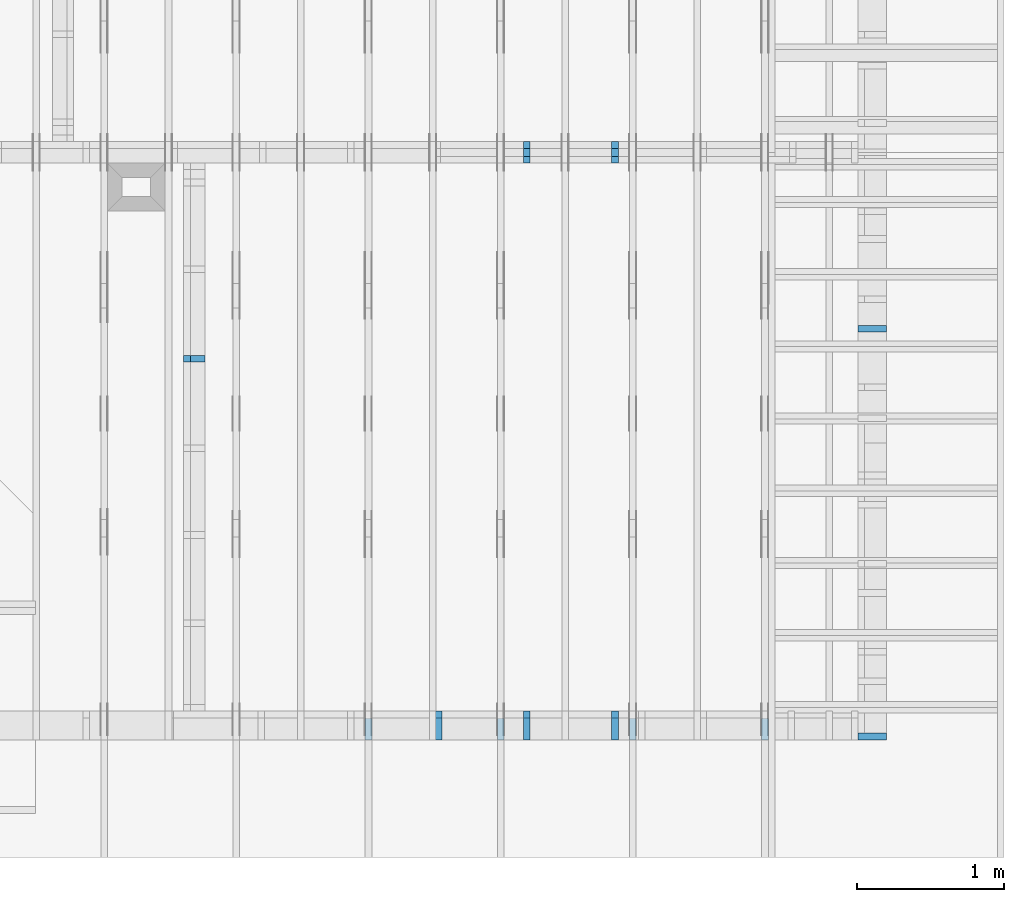
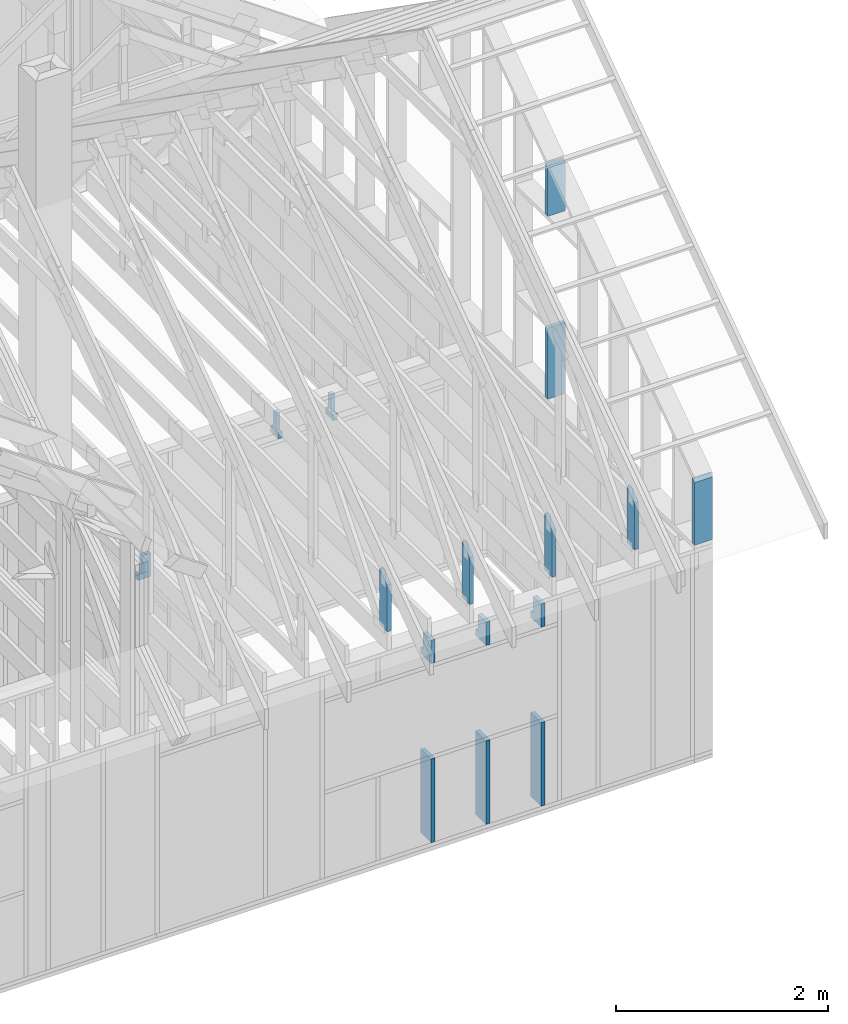
# One storey, part 39 of 70: 16 members, 8 elements without a shape of their own.
"""IFC2X3 building model written with IfcOpenShell, lengths in millimetres."""

import ifcopenshell
import ifcopenshell.guid

model = None  # the IFC model being written
_history = None  # IfcOwnerHistory: only IFC2X3 demands one
_inside = {}  # id of a spatial element -> (the spatial element, [elements in it])
_under = {}  # id of a project, library or spatial element -> (it, [spatial elements below it])
_declared = {}  # id of a project -> (the project, [libraries it declares])
_typed = {}  # id of a type object -> (the type object, [elements of that type])
_made_of = {}  # id of a material, layer set ... -> (it, [elements and type objects made of it])


def new_model(schema):
    """Start an empty IFC model of exactly this schema.

    Asked for "IFC4X3", IfcOpenShell would pick the latest addendum, in which some entities
    have other attributes; the version numbers below select the first issue.
    IFC2X3 requires an IfcOwnerHistory on every rooted entity: one is made here for all.
    """
    global model, _history
    if schema == "IFC4X3":
        model = ifcopenshell.file(schema_version=(4, 3, 0, 0))
    else:
        model = ifcopenshell.file(schema=schema)
    _inside.clear()
    _under.clear()
    _declared.clear()
    _typed.clear()
    _made_of.clear()
    _history = None
    if model.schema == "IFC2X3":
        org = make("IfcOrganization", Name="unknown")
        user = make(
            "IfcPersonAndOrganization",
            ThePerson=make("IfcPerson", FamilyName="unknown"),
            TheOrganization=org,
        )
        app = make(
            "IfcApplication",
            ApplicationDeveloper=org,
            Version="unknown",
            ApplicationFullName="unknown",
            ApplicationIdentifier="unknown",
        )
        _history = make(
            "IfcOwnerHistory",
            OwningUser=user,
            OwningApplication=app,
            ChangeAction="ADDED",
            CreationDate=0,
        )
    return model


def make(cls, **values):
    """One entity of the class cls with the attributes given. An attribute that is None is left unset."""
    return model.create_entity(
        cls, **{name: value for name, value in values.items() if value is not None}
    )


def rooted(cls, **values):
    """An entity with a GlobalId (a new one), such as an element, a storey or a relation."""
    return make(cls, GlobalId=ifcopenshell.guid.new(), OwnerHistory=_history, **values)


def si_unit(unit_type, name, prefix=None):
    """IfcSIUnit, for example si_unit("LENGTHUNIT", "METRE", prefix="MILLI")."""
    return make("IfcSIUnit", UnitType=unit_type, Prefix=prefix, Name=name)


def assignment(units):
    """IfcUnitAssignment: the units of a project."""
    return None if units is None else make("IfcUnitAssignment", Units=units)


def point(xyz):
    """IfcCartesianPoint."""
    return None if xyz is None else make("IfcCartesianPoint", Coordinates=xyz)


def direction(xyz):
    """IfcDirection."""
    return None if xyz is None else make("IfcDirection", DirectionRatios=xyz)


def frame(location, z_axis=None, x_axis=None):
    """IfcAxis2Placement3D, a coordinate frame: its origin and axes. An axis left out is left unset."""
    return make(
        "IfcAxis2Placement3D",
        Location=point(location),
        Axis=direction(z_axis),
        RefDirection=direction(x_axis),
    )


def frame_2d(location, x_axis=None):
    """IfcAxis2Placement2D, a coordinate frame in the plane: its origin and x axis."""
    return make(
        "IfcAxis2Placement2D", Location=point(location), RefDirection=direction(x_axis)
    )


def origin():
    """The frame at (0, 0, 0) with its axes left unset."""
    return frame((0.0, 0.0, 0.0))


def origin_with_axes():
    """The frame at (0, 0, 0) with the z axis (0, 0, 1) and the x axis (1, 0, 0) written out."""
    return frame((0.0, 0.0, 0.0), z_axis=(0.0, 0.0, 1.0), x_axis=(1.0, 0.0, 0.0))


def origin_2d():
    """The frame at (0, 0) in the plane with its x axis left unset."""
    return frame_2d((0.0, 0.0))


def place(relative_to, where):
    """IfcLocalPlacement: puts the frame where relative to a parent placement (None: the world)."""
    return make(
        "IfcLocalPlacement", PlacementRelTo=relative_to, RelativePlacement=where
    )


def context(
    kind, dimensions, precision=None, world=None, true_north=None, identifier=None
):
    """IfcGeometricRepresentationContext, for example the 3D "Model" context."""
    return make(
        "IfcGeometricRepresentationContext",
        ContextIdentifier=identifier,
        ContextType=kind,
        CoordinateSpaceDimension=dimensions,
        Precision=precision,
        WorldCoordinateSystem=world,
        TrueNorth=true_north,
    )


def project(units=None, contexts=None):
    """IfcProject with its units and contexts."""
    return rooted(
        "IfcProject",
        Name="project",
        RepresentationContexts=contexts,
        UnitsInContext=assignment(units),
    )


def spatial(cls, under=None, at=None, **own):
    """A site, building, storey or space (cls), placed at a placement, below another one or the project."""
    s = rooted(cls, ObjectPlacement=at, **own)
    if under is not None:
        _under.setdefault(under.id(), (under, []))[1].append(s)
    return s


def faces_of(points, faces, orient=None, outer=None):
    """IfcFace entities. A face is a list of loops; a loop is a list of indices into points, from 0.

    orient and outer hold one flag for each loop. By default every Orientation is true, the
    first loop of a face is its IfcFaceOuterBound and the others are IfcFaceBound.
    """
    made = []
    for i, loops in enumerate(faces):
        bounds = []
        for j, loop in enumerate(loops):
            is_outer = j == 0 if outer is None else outer[i][j]
            bounds.append(
                make(
                    "IfcFaceOuterBound" if is_outer else "IfcFaceBound",
                    Bound=make("IfcPolyLoop", Polygon=[points[k] for k in loop]),
                    Orientation=True if orient is None else orient[i][j],
                )
            )
        made.append(make("IfcFace", Bounds=bounds))
    return made


def faceted_brep(points, faces, orient=None, outer=None, voids=None):
    """IfcFacetedBrep: a solid bounded by flat faces; with voids (closed shells), ...WithVoids."""
    shared = [point(p) for p in points]
    hull = make("IfcClosedShell", CfsFaces=faces_of(shared, faces, orient, outer))
    if voids is None:
        return make("IfcFacetedBrep", Outer=hull)
    return make(
        "IfcFacetedBrepWithVoids",
        Outer=hull,
        Voids=[
            make(cls, CfsFaces=faces_of(shared, fs, o, b)) for cls, fs, o, b in voids
        ],
    )


def shape(context_of_items, identifier, shape_type, items):
    """IfcShapeRepresentation: the items that make up one representation, for example the "Body"."""
    return make(
        "IfcShapeRepresentation",
        ContextOfItems=context_of_items,
        RepresentationIdentifier=identifier,
        RepresentationType=shape_type,
        Items=items,
    )


def made_of(thing, what):
    """Note that an element or type object is made of a material, layer set ...; save() writes the relation."""
    if what is not None:
        _made_of.setdefault(what.id(), (what, []))[1].append(thing)
    return thing


def element(
    cls,
    number,
    at=None,
    inside=None,
    cuts=None,
    type_object=None,
    material=None,
    context=None,
    identifier="Body",
    shape_type=None,
    held_by="IfcProductDefinitionShape",
    body=None,
    shapes=None,
    **own,
):
    """One element of the class cls, such as IfcWall. Its Tag is "e" and its number.

    at: its placement. inside: the storey or other place that contains it. cuts: it is an
    opening in that element (IfcRelVoidsElement). A single representation is given by context,
    identifier, shape_type and body (its items); several are given by shapes. held_by: the class
    of the entity that holds the representations. save() writes the other relations.
    """
    e = rooted(cls, Tag="e%d" % number, ObjectPlacement=at, **own)
    if body is not None:
        shapes = [shape(context, identifier, shape_type, body)]
    if shapes is not None:
        e.Representation = make(held_by, Representations=shapes)
    if inside is not None:
        _inside.setdefault(inside.id(), (inside, []))[1].append(e)
    if cuts is not None:
        rooted(
            "IfcRelVoidsElement", RelatingBuildingElement=cuts, RelatedOpeningElement=e
        )
    if type_object is not None:
        _typed.setdefault(type_object.id(), (type_object, []))[1].append(e)
    return made_of(e, material)


def aggregate(whole, parts):
    """IfcRelAggregates: a whole, such as a stair, and the parts it consists of."""
    return rooted("IfcRelAggregates", RelatingObject=whole, RelatedObjects=parts)


def save(model, path):
    """Write the relations noted so far, then the file.

    IfcRelAggregates (storeys below a building ...), IfcRelContainedInSpatialStructure (elements
    in a storey), IfcRelDefinesByType, IfcRelAssociatesMaterial and IfcRelDeclares: one each for
    every whole, place, type object, material and project.
    """
    for whole, parts in _under.values():
        aggregate(whole, parts)
    for where, things in _inside.values():
        rooted(
            "IfcRelContainedInSpatialStructure",
            RelatedElements=things,
            RelatingStructure=where,
        )
    for kind, things in _typed.values():
        rooted("IfcRelDefinesByType", RelatedObjects=things, RelatingType=kind)
    for what, things in _made_of.values():
        rooted("IfcRelAssociatesMaterial", RelatedObjects=things, RelatingMaterial=what)
    for by, libraries in _declared.values():
        rooted("IfcRelDeclares", RelatingContext=by, RelatedDefinitions=libraries)
    model.write(path)


model = new_model("IFC2X3")

# Units and contexts
model_context = context("Model", 3, precision=1e-05, world=origin())
plan_context = context("Plan", 2, precision=1e-05, world=origin_2d())
ifc_project = project(units=[si_unit("LENGTHUNIT", "METRE", prefix="MILLI"), si_unit("AREAUNIT", "SQUARE_METRE"), si_unit("VOLUMEUNIT", "CUBIC_METRE"), si_unit("SOLIDANGLEUNIT", "STERADIAN"), si_unit("PLANEANGLEUNIT", "RADIAN"), si_unit("MASSUNIT", "GRAM"), si_unit("TIMEUNIT", "SECOND"), si_unit("THERMODYNAMICTEMPERATUREUNIT", "DEGREE_CELSIUS"), si_unit("LUMINOUSINTENSITYUNIT", "LUMEN")], contexts=[model_context, plan_context])

# Site, building, storey
site_placement = place(None, origin_with_axes())
site = spatial("IfcSite", under=ifc_project, at=site_placement, CompositionType="ELEMENT")
building_placement = place(site_placement, origin_with_axes())
building = spatial("IfcBuilding", under=site, at=building_placement, Name="Layout 1", CompositionType="ELEMENT")
storey_placement = place(building_placement, origin_with_axes())
storey = spatial("IfcBuildingStorey", under=building, at=storey_placement, Name="Storey 1", CompositionType="ELEMENT", Elevation=0.0)

# Assembly, members
assembly_1_placement = place(storey_placement, frame((-48.55339059325575, 0.0, -2470.0), z_axis=(0.0, -1.0, 6.123031769111886e-17), x_axis=(1.0, 0.0, 0.0)))
assembly_1 = element("IfcElementAssembly", 1, at=assembly_1_placement, inside=storey, Name="VE4", AssemblyPlace="FACTORY", PredefinedType="NOTDEFINED")
member_1_placement = place(assembly_1_placement, frame((8977.500000001819, 2425.0, -195.0), z_axis=(0.0, 0.0, 1.0), x_axis=(-1.836909530733566e-16, -1.0, 0.0)))
member_1 = element("IfcMember", 2, at=member_1_placement, Name="S40", context=model_context, shape_type="Brep", body=[
    faceted_brep([(0.0, 45.0, 45.0), (195.00000000186265, 45.0, 45.00000000000002), (195.00000000186265, 0.0, 45.00000000000002), (0.0, 0.0, 45.0), (195.00000000186265, 45.000000000010914, 0.0), (195.00000000186265, 45.000000000010914, 45.0), (195.00000000186265, 0.0, 45.0), (195.00000000186265, 0.0, 0.0), (2.755364296100349e-15, -3.3742366240998092e-31, 45.0), (1.1939911949768178e-14, -1.462169203776584e-30, 195.0), (1.7450640541968876e-14, 45.0, 195.0), (8.266092888301046e-15, 45.0, 45.0), (270.0, -4.959655732980628e-14, 3.0368129616898283e-30), (270.0, -3.76566453800381e-14, 195.0), (2.193253805664876e-30, 1.1939911949768178e-14, 195.0), (5.061354936149714e-31, 2.755364296100349e-15, 45.0), (195.00000000186265, -3.306437155354634e-14, 45.0), (195.00000000186265, -3.5819735849646686e-14, 2.193253805685826e-30), (-1.6871183120499046e-31, 45.000000000010914, 45.0), (-7.31084601888292e-31, 45.0000000000109, 195.0), (270.0, 45.000000000010886, 195.0), (270.0, 45.0000000000109, -1.1832913578315177e-30), (195.00000000186265, 45.0000000000109, -7.888609052210118e-31), (195.00000000186265, 45.0000000000109, 45.0), (270.0, 45.00000000001455, 0.0), (270.0, 45.00000000001455, 195.0), (270.0, 0.0, 195.0), (270.0, 0.0, 0.0), (270.0, 45.00000000001455, 195.0), (0.0, 45.00000000001455, 195.0), (0.0, 0.0, 195.0), (270.0, 0.0, 195.0), (195.00000000186265, 45.000000000010914, 2.3879823899764457e-14), (270.0, 45.000000000010914, 3.3064371553204186e-14), (270.0, 0.0, 3.3064371553204186e-14), (195.00000000186265, 0.0, 2.3879823899764457e-14)], [[[0, 1, 2, 3]], [[4, 5, 6, 7]], [[8, 9, 10, 11]], [[12, 13, 14, 15, 16, 17]], [[18, 19, 20, 21, 22, 23]], [[24, 25, 26, 27]], [[28, 29, 30, 31]], [[32, 33, 34, 35]]]),
])
member_2_placement = place(assembly_1_placement, frame((8977.500000001834, 1055.0, -195.0), z_axis=(0.0, 0.0, 1.0), x_axis=(-1.836909530733566e-16, -1.0, 0.0)))
member_2 = element("IfcMember", 3, at=member_2_placement, Name="S32", context=model_context, shape_type="Brep", body=[
    faceted_brep([(964.9999999999999, 45.0, 195.0), (0.0, 45.0, 195.0), (0.0, 0.0, 195.0), (965.0, 0.0, 195.0), (0.0, 45.0, 0.0), (964.9999999999999, 45.0, 1.1817451314385938e-13), (965.0, 0.0, 1.181745131438594e-13), (0.0, 0.0, 0.0), (0.0, 0.0, 0.0), (1.1939911949768178e-14, -1.462169203776584e-30, 195.0), (1.7450640541968876e-14, 45.0, 195.0), (5.510728592200698e-15, 45.0, -3.3742366240998092e-31), (965.0, -1.772617697157891e-13, 1.085379447418772e-29), (965.0, -1.6532185776602093e-13, 195.0), (2.193253805664876e-30, 1.1939911949768178e-14, 195.0), (0.0, 0.0, 0.0), (965.0, 45.0, 1.262177448353619e-29), (965.0, 45.0, 195.0), (965.0, 0.0, 195.0), (965.0, 0.0, 0.0), (0.0, 45.0, 0.0), (-7.31084601888292e-31, 44.999999999999986, 195.0), (964.9999999999999, 44.99999999999993, 195.0), (964.9999999999999, 44.99999999999994, -3.549874073494553e-30)], [[[0, 1, 2, 3]], [[4, 5, 6, 7]], [[8, 9, 10, 11]], [[12, 13, 14, 15]], [[16, 17, 18, 19]], [[20, 21, 22, 23]]]),
])
member_3_placement = place(assembly_1_placement, frame((9577.500000001834, 2425.0, -195.00000000000003), z_axis=(0.0, 0.0, 1.0), x_axis=(-1.836909530733566e-16, -1.0, 0.0)))
member_3 = element("IfcMember", 4, at=member_3_placement, Name="S40", context=model_context, shape_type="Brep", body=[
    faceted_brep([(0.0, 44.99999999998545, 45.00000000000003), (195.00000000186265, 44.99999999998545, 45.00000000000005), (195.00000000186265, 0.0, 45.00000000000005), (0.0, 0.0, 45.00000000000003), (195.00000000186265, 44.99999999999636, 2.842170943040401e-14), (195.00000000186265, 44.99999999999636, 45.00000000000003), (195.00000000186265, 0.0, 45.00000000000003), (195.00000000186265, 0.0, 2.842170943040401e-14), (2.7553642961003504e-15, -3.3742366240998114e-31, 45.00000000000003), (1.193991194976818e-14, -1.4621692037765842e-30, 195.00000000000003), (1.7450640541967096e-14, 44.99999999998545, 195.00000000000006), (8.266092888299267e-15, 44.99999999998545, 45.00000000000003), (270.0, -4.959655732980628e-14, 2.842170943040401e-14), (270.0, -3.76566453800381e-14, 195.00000000000003), (2.1932538056648764e-30, 1.193991194976818e-14, 195.00000000000003), (5.061354936149717e-31, 2.7553642961003504e-15, 45.00000000000003), (195.00000000186265, -3.306437155354634e-14, 45.00000000000003), (195.00000000186265, -3.5819735849646686e-14, 2.842170943040401e-14), (-1.6871183120499057e-31, 44.99999999999636, 45.00000000000003), (-7.310846018882921e-31, 44.99999999999635, 195.00000000000003), (270.0, 44.999999999996334, 195.00000000000003), (270.0, 44.99999999999635, 2.8421709430404004e-14), (195.00000000186265, 44.99999999999635, 2.8421709430404004e-14), (195.00000000186265, 44.99999999999635, 45.00000000000003), (270.0, 45.0, 0.0), (270.0, 45.0, 195.00000000000003), (270.0, 0.0, 195.00000000000003), (270.0, 0.0, 0.0), (270.0, 45.0, 195.00000000000003), (0.0, 45.0, 195.00000000000003), (0.0, 0.0, 195.00000000000003), (270.0, 0.0, 195.00000000000003), (195.00000000186265, 44.99999999999636, 5.2301533330168465e-14), (270.0, 44.99999999999636, 6.148608098360819e-14), (270.0, 0.0, 6.148608098360819e-14), (195.00000000186265, 0.0, 5.2301533330168465e-14)], [[[0, 1, 2, 3]], [[4, 5, 6, 7]], [[8, 9, 10, 11]], [[12, 13, 14, 15, 16, 17]], [[18, 19, 20, 21, 22, 23]], [[24, 25, 26, 27]], [[28, 29, 30, 31]], [[32, 33, 34, 35]]]),
])
member_4_placement = place(assembly_1_placement, frame((9577.500000001834, 1055.0, -195.0), z_axis=(0.0, 0.0, 1.0), x_axis=(-1.836909530733566e-16, -1.0, 0.0)))
member_4 = element("IfcMember", 5, at=member_4_placement, Name="S32", context=model_context, shape_type="Brep", body=[
    faceted_brep([(965.0, 45.0, 195.0), (0.0, 45.0, 195.0), (0.0, 0.0, 195.0), (965.0, 0.0, 195.0), (0.0, 45.0, 0.0), (965.0, 45.0, 1.181745131438594e-13), (965.0, 0.0, 1.181745131438594e-13), (0.0, 0.0, 0.0), (0.0, 0.0, 0.0), (1.1939911949768178e-14, -1.462169203776584e-30, 195.0), (1.7450640541967093e-14, 44.99999999998545, 195.0), (5.510728592198916e-15, 44.99999999998545, -3.374236624098718e-31), (965.0, -1.772617697157891e-13, 1.085379447418772e-29), (965.0, -1.6532185776602093e-13, 195.0), (2.193253805664876e-30, 1.1939911949768178e-14, 195.0), (0.0, 0.0, 0.0), (965.0, 45.0, 0.0), (965.0, 45.0, 195.0), (965.0, 0.0, 195.0), (965.0, 0.0, 0.0), (0.0, 44.99999999998545, 0.0), (2.0194839173657902e-28, 44.999999999985434, 195.0), (965.0, 44.99999999999995, 195.0), (965.0, 44.99999999999996, -2.3665827156630354e-30)], [[[0, 1, 2, 3]], [[4, 5, 6, 7]], [[8, 9, 10, 11]], [[12, 13, 14, 15]], [[16, 17, 18, 19]], [[20, 21, 22, 23]]]),
])
member_5_placement = place(assembly_1_placement, frame((10177.500000001834, 2425.0, -195.00000000000003), z_axis=(0.0, 0.0, 1.0), x_axis=(-1.836909530733566e-16, -1.0, 0.0)))
member_5 = element("IfcMember", 6, at=member_5_placement, Name="S40", context=model_context, shape_type="Brep", body=[
    faceted_brep([(0.0, 45.0, 45.00000000000003), (195.00000000186265, 45.0, 45.00000000000005), (195.00000000186265, 0.0, 45.00000000000005), (0.0, 0.0, 45.00000000000003), (195.00000000186265, 45.0, 2.842170943040401e-14), (195.00000000186265, 45.0, 45.00000000000003), (195.00000000186265, 0.0, 45.00000000000003), (195.00000000186265, 0.0, 2.842170943040401e-14), (2.7553642961003504e-15, -3.3742366240998114e-31, 45.00000000000003), (1.193991194976818e-14, -1.4621692037765842e-30, 195.00000000000003), (1.7450640541968876e-14, 45.0, 195.00000000000003), (8.266092888301048e-15, 45.0, 45.00000000000003), (270.0, -4.959655732980628e-14, 2.842170943040401e-14), (270.0, -3.76566453800381e-14, 195.00000000000003), (2.1932538056648764e-30, 1.193991194976818e-14, 195.00000000000003), (5.061354936149717e-31, 2.7553642961003504e-15, 45.00000000000003), (195.00000000186265, -3.306437155354634e-14, 45.00000000000003), (195.00000000186265, -3.5819735849646686e-14, 2.842170943040401e-14), (-1.6871183120499057e-31, 45.0, 45.00000000000003), (-7.310846018882921e-31, 44.999999999999986, 195.00000000000003), (270.0, 44.99999999999997, 195.00000000000003), (270.0, 44.999999999999986, 2.842170943040401e-14), (195.00000000186265, 44.999999999999986, 2.842170943040401e-14), (195.00000000186265, 44.999999999999986, 45.00000000000003), (270.0, 45.0, 0.0), (270.0, 45.0, 195.00000000000003), (270.0, 0.0, 195.00000000000003), (270.0, 0.0, 0.0), (270.0, 45.0, 195.00000000000003), (0.0, 45.0, 195.00000000000003), (0.0, 0.0, 195.00000000000003), (270.0, 0.0, 195.00000000000003), (195.00000000186265, 45.0, 5.2301533330168465e-14), (270.0, 45.0, 6.148608098360819e-14), (270.0, 0.0, 6.148608098360819e-14), (195.00000000186265, 0.0, 5.2301533330168465e-14)], [[[0, 1, 2, 3]], [[4, 5, 6, 7]], [[8, 9, 10, 11]], [[12, 13, 14, 15, 16, 17]], [[18, 19, 20, 21, 22, 23]], [[24, 25, 26, 27]], [[28, 29, 30, 31]], [[32, 33, 34, 35]]]),
])
member_6_placement = place(assembly_1_placement, frame((10177.500000001819, 1055.0, -195.0), z_axis=(0.0, 0.0, 1.0), x_axis=(-1.836909530733566e-16, -1.0, 0.0)))
member_6 = element("IfcMember", 7, at=member_6_placement, Name="S32", context=model_context, shape_type="Brep", body=[
    faceted_brep([(965.0, 45.00000000001455, 195.0), (0.0, 45.00000000001455, 195.0), (0.0, 2.9103830456733704e-11, 195.0), (965.0, 2.9103830456733704e-11, 195.0), (0.0, 45.00000000001455, 0.0), (965.0, 45.00000000001455, 1.181745131438594e-13), (965.0, 2.9103830456733704e-11, 1.181745131438594e-13), (0.0, 2.9103830456733704e-11, 0.0), (3.564073569788531e-27, 2.9103830456733704e-11, -2.1822935695267187e-43), (1.1939911949771742e-14, 2.9103830456733704e-11, 195.0), (1.745064054197066e-14, 45.00000000001455, 195.0), (5.51072859220248e-15, 45.00000000001455, -3.3742366241009005e-31), (965.0, 6.425269116674265e-13, -3.934212692648999e-29), (965.0, 6.544668236171947e-13, 195.0), (3.5215073399348835e-28, 2.911577036868347e-11, 195.0), (0.0, 2.9103830456733704e-11, 0.0), (965.0, 45.00000000001455, 0.0), (965.0, 45.00000000001455, 195.0), (965.0, 0.0, 195.0), (965.0, 0.0, 0.0), (-1.2154326714572542e-63, 45.00000000001455, 0.0), (-7.31084601888292e-31, 45.00000000001454, 195.0), (965.0, 45.00000000001448, 195.0), (965.0, 45.000000000014495, -3.549874073494553e-30)], [[[0, 1, 2, 3]], [[4, 5, 6, 7]], [[8, 9, 10, 11]], [[12, 13, 14, 15]], [[16, 17, 18, 19]], [[20, 21, 22, 23]]]),
])
aggregate(assembly_1, [member_1, member_2, member_3, member_4, member_5, member_6])

assembly_2_placement = place(storey_placement, frame((-48.55339059327651, 3927.500000000001, -2470.0), z_axis=(0.0, -1.0, 6.123031769111886e-17), x_axis=(1.0, 0.0, 0.0)))
assembly_2 = element("IfcElementAssembly", 8, at=assembly_2_placement, inside=storey, Name="VE8", AssemblyPlace="FACTORY", PredefinedType="NOTDEFINED")
member_7_placement = place(assembly_2_placement, frame((9577.500000001834, 2425.0, -145.0), z_axis=(0.0, 0.0, 1.0), x_axis=(-1.836909530733566e-16, -1.0, 0.0)))
member_7 = element("IfcMember", 9, at=member_7_placement, Name="S46", context=model_context, shape_type="Brep", body=[
    faceted_brep([(195.0, 45.0, -1.14050354233233e-25), (195.0, 45.0, 45.0), (195.0, 3.637978807091713e-12, 45.0), (195.0, 3.637978807091713e-12, -1.14050354233233e-25), (195.0, 45.0, 100.0), (195.0, 45.0, 145.0), (195.0, 3.637978807091713e-12, 145.0), (195.0, 3.637978807091713e-12, 100.0), (195.0, 45.0, 100.0), (0.0, 45.0, 100.0), (0.0, 3.637978807091713e-12, 100.0), (195.0, 3.637978807091713e-12, 100.0), (270.0, 45.0, 145.0), (195.0, 45.0, 145.0), (195.0, 3.637978807091713e-12, 145.0), (270.0, 3.637978807091713e-12, 145.0), (270.0, 3.5883822497619067e-12, 3.0368129616898283e-30), (270.0, 3.597260645827119e-12, 145.0), (195.0, 3.6110374673076207e-12, 145.0), (195.0, 3.6082821030115203e-12, 100.0), (1.124745541366603e-30, 3.644101838860825e-12, 100.0), (5.061354936149714e-31, 3.640734171387813e-12, 45.0), (195.0, 3.6049144355385088e-12, 45.0), (195.0, 3.6021590712424084e-12, 2.193253805685817e-30), (0.0, 45.0, 45.0), (195.00000000186265, 45.0, 45.00000000000002), (195.00000000186265, 1.4551915228366852e-11, 45.00000000000002), (0.0, 1.4551915228366852e-11, 45.0), (2.755364296102131e-15, 1.4551915228366852e-11, 45.0), (6.123031769113668e-15, 1.4551915228366852e-11, 100.0), (1.1633760361312584e-14, 45.0, 100.0), (8.266092888301046e-15, 45.0, 45.0), (-1.6871183120499046e-31, 45.0, 45.0), (-3.7491518045553436e-31, 44.99999999999999, 100.0), (195.0, 44.99999999999998, 100.0), (195.0, 44.99999999999998, 145.0), (270.0, 44.99999999999997, 145.0), (270.0, 44.999999999999986, -1.1832913578315177e-30), (195.0, 44.999999999999986, -7.888609052210118e-31), (195.0, 44.999999999999986, 45.0), (270.0, 45.0, 2.842170943040401e-14), (270.0, 45.0, 145.0), (270.0, 0.0, 145.0), (270.0, 0.0, 0.0), (195.00000000186265, 45.0, 2.3879823899764457e-14), (270.0, 45.0, 3.3064371553204186e-14), (270.0, 0.0, 3.3064371553204186e-14), (195.00000000186265, 0.0, 2.3879823899764457e-14)], [[[0, 1, 2, 3]], [[4, 5, 6, 7]], [[8, 9, 10, 11]], [[12, 13, 14, 15]], [[16, 17, 18, 19, 20, 21, 22, 23]], [[24, 25, 26, 27]], [[28, 29, 30, 31]], [[32, 33, 34, 35, 36, 37, 38, 39]], [[40, 41, 42, 43]], [[44, 45, 46, 47]]]),
])
member_8_placement = place(assembly_2_placement, frame((10177.500000001834, 2425.0, -145.0), z_axis=(0.0, 0.0, 1.0), x_axis=(-1.836909530733566e-16, -1.0, 0.0)))
member_8 = element("IfcMember", 10, at=member_8_placement, Name="S46", context=model_context, shape_type="Brep", body=[
    faceted_brep([(195.0, 45.00000000000364, -1.14050354233233e-25), (195.0, 45.00000000000364, 45.0), (195.0, 3.637978807091713e-12, 45.0), (195.0, 3.637978807091713e-12, -1.14050354233233e-25), (195.0, 45.00000000000364, 100.0), (195.0, 45.00000000000364, 145.0), (195.0, 3.637978807091713e-12, 145.0), (195.0, 3.637978807091713e-12, 100.0), (195.0, 45.00000000000364, 100.0), (0.0, 45.00000000000364, 100.0), (0.0, 3.637978807091713e-12, 100.0), (195.0, 3.637978807091713e-12, 100.0), (270.0, 45.0, 145.0), (195.0, 45.0, 145.0), (195.0, 3.637978807091713e-12, 145.0), (270.0, 3.637978807091713e-12, 145.0), (270.0, 3.5883822497619067e-12, 3.0368129616898283e-30), (270.0, 3.597260645827119e-12, 145.0), (195.0, 3.6110374673076207e-12, 145.0), (195.0, 3.6082821030115203e-12, 100.0), (1.124745541366603e-30, 3.644101838860825e-12, 100.0), (5.061354936149714e-31, 3.640734171387813e-12, 45.0), (195.0, 3.6049144355385088e-12, 45.0), (195.0, 3.6021590712424084e-12, 2.193253805685817e-30), (0.0, 45.00000000001455, 45.0), (195.00000000186265, 45.00000000001455, 45.00000000000002), (195.00000000186265, 1.4551915228366852e-11, 45.00000000000002), (0.0, 1.4551915228366852e-11, 45.0), (2.755364296102131e-15, 1.4551915228366852e-11, 45.0), (6.123031769113668e-15, 1.4551915228366852e-11, 100.0), (1.1633760361314367e-14, 45.00000000001455, 100.0), (8.26609288830283e-15, 45.00000000001455, 45.0), (-1.6871183120499046e-31, 45.00000000000364, 45.0), (-3.7491518045553436e-31, 45.00000000000363, 100.0), (195.0, 45.00000000000362, 100.0), (195.0, 45.00000000000362, 145.0), (270.0, 45.00000000000361, 145.0), (270.0, 45.000000000003624, -1.1832913578315177e-30), (195.0, 45.000000000003624, -7.888609052210118e-31), (195.0, 45.000000000003624, 45.0), (270.0, 45.0, 2.842170943040401e-14), (270.0, 45.0, 145.0), (270.0, 0.0, 145.0), (270.0, 0.0, 0.0), (195.00000000186265, 45.00000000000364, 2.3879823899764457e-14), (270.0, 45.00000000000364, 3.3064371553204186e-14), (270.0, 0.0, 3.3064371553204186e-14), (195.00000000186265, 0.0, 2.3879823899764457e-14)], [[[0, 1, 2, 3]], [[4, 5, 6, 7]], [[8, 9, 10, 11]], [[12, 13, 14, 15]], [[16, 17, 18, 19, 20, 21, 22, 23]], [[24, 25, 26, 27]], [[28, 29, 30, 31]], [[32, 33, 34, 35, 36, 37, 38, 39]], [[40, 41, 42, 43]], [[44, 45, 46, 47]]]),
])
aggregate(assembly_2, [member_7, member_8])

# Assembly, member
assembly_3_placement = place(storey_placement, frame((10250.0, 8000.0, -9.081170196248781e-13), z_axis=(-1.0, 1.836909530733566e-16, 6.123031769111886e-17), x_axis=(-1.836909530733566e-16, -1.0, 0.0)))
assembly_3 = element("IfcElementAssembly", 11, at=assembly_3_placement, inside=storey, Name="T3", AssemblyPlace="FACTORY", PredefinedType="TRUSS")
member_9_placement = place(assembly_3_placement, frame((7855.0, 863.4790482301833, -45.0), z_axis=(0.0, 0.0, 1.0), x_axis=(-1.836909530733566e-16, -1.0, 0.0)))
member_9 = element("IfcMember", 12, at=member_9_placement, Name="E3", context=model_context, shape_type="Brep", body=[
    faceted_brep([(643.4790482301833, 145.0, 45.0), (101.53009304048464, 145.0, 45.0), (0.0, 1.8480932340025902e-09, 45.0), (643.4790482301833, 1.8480932340025902e-09, 45.0), (101.53009304048464, 145.0, 1.2433439704155462e-14), (643.4790482301833, 145.0, 7.880085310142583e-14), (643.4790482301833, 1.8480932340025902e-09, 7.880085310142583e-14), (0.0, 1.8480932340025902e-09, 0.0), (5.452511878872964e-15, 1.8480894161126704e-09, -4.075666256077759e-31), (7.70957417477943e-15, 1.8480878357006368e-09, 45.0), (101.53009304048466, 145.00000000183354, 45.0), (101.53009304048466, 145.00000000183354, 3.1438766626360792e-31), (643.4790482301833, -3.3424355386714936e-13, 2.0465838989492066e-29), (643.4790482301833, -3.31488189571049e-13, 45.0), (7.91492914862017e-27, 1.8480959893668863e-09, 45.0), (0.0, 1.8480932340025902e-09, 0.0), (643.4790482301833, 145.0, 0.0), (643.4790482301833, 145.0, 45.0), (643.4790482301833, 0.0, 45.0), (643.4790482301833, 0.0, 0.0), (101.53009304048464, 145.00000000183357, 1.5777218104420236e-30), (101.53009304048464, 145.00000000183354, 45.0), (643.4790482301833, 145.00000000000006, 45.0), (643.4790482301833, 145.00000000000006, 4.733165431326071e-30)], [[[0, 1, 2, 3]], [[4, 5, 6, 7]], [[8, 9, 10, 11]], [[12, 13, 14, 15]], [[16, 17, 18, 19]], [[20, 21, 22, 23]]]),
])
aggregate(assembly_3, [member_9])

assembly_4_placement = place(storey_placement, frame((9350.0, 8000.0, -9.081170196248781e-13), z_axis=(-1.0, 1.836909530733566e-16, 6.123031769111886e-17), x_axis=(-1.836909530733566e-16, -1.0, 0.0)))
assembly_4 = element("IfcElementAssembly", 13, at=assembly_4_placement, inside=storey, Name="T3", AssemblyPlace="FACTORY", PredefinedType="TRUSS")
member_10_placement = place(assembly_4_placement, frame((7855.0, 863.4790482301833, -45.0), z_axis=(0.0, 0.0, 1.0), x_axis=(-1.836909530733566e-16, -1.0, 0.0)))
member_10 = element("IfcMember", 14, at=member_10_placement, Name="E3", context=model_context, shape_type="Brep", body=[
    faceted_brep([(643.4790482301833, 145.0, 45.0), (101.53009304048464, 145.0, 45.0), (0.0, 1.8480932340025902e-09, 45.0), (643.4790482301833, 1.8480932340025902e-09, 45.0), (101.53009304048464, 145.0, 1.2433439704155462e-14), (643.4790482301833, 145.0, 7.880085310142583e-14), (643.4790482301833, 1.8480932340025902e-09, 7.880085310142583e-14), (0.0, 1.8480932340025902e-09, 0.0), (5.452511878872964e-15, 1.8480894161126704e-09, -4.075666256077759e-31), (7.70957417477943e-15, 1.8480878357006368e-09, 45.0), (101.53009304048466, 145.00000000183354, 45.0), (101.53009304048466, 145.00000000183354, 3.1438766626360792e-31), (643.4790482301833, -3.3424355386714936e-13, 2.0465838989492066e-29), (643.4790482301833, -3.31488189571049e-13, 45.0), (7.91492914862017e-27, 1.8480959893668863e-09, 45.0), (0.0, 1.8480932340025902e-09, 0.0), (643.4790482301833, 145.0, 0.0), (643.4790482301833, 145.0, 45.0), (643.4790482301833, 0.0, 45.0), (643.4790482301833, 0.0, 0.0), (101.53009304048464, 145.00000000183357, 1.5777218104420236e-30), (101.53009304048464, 145.00000000183354, 45.0), (643.4790482301833, 145.00000000000006, 45.0), (643.4790482301833, 145.00000000000006, 4.733165431326071e-30)], [[[0, 1, 2, 3]], [[4, 5, 6, 7]], [[8, 9, 10, 11]], [[12, 13, 14, 15]], [[16, 17, 18, 19]], [[20, 21, 22, 23]]]),
])
aggregate(assembly_4, [member_10])

assembly_5_placement = place(storey_placement, frame((8450.0, 8000.0, -9.081170196248781e-13), z_axis=(-1.0, 1.836909530733566e-16, 6.123031769111886e-17), x_axis=(-1.836909530733566e-16, -1.0, 0.0)))
assembly_5 = element("IfcElementAssembly", 15, at=assembly_5_placement, inside=storey, Name="T3", AssemblyPlace="FACTORY", PredefinedType="TRUSS")
member_11_placement = place(assembly_5_placement, frame((7855.0, 863.4790482301833, -45.0), z_axis=(0.0, 0.0, 1.0), x_axis=(-1.836909530733566e-16, -1.0, 0.0)))
member_11 = element("IfcMember", 16, at=member_11_placement, Name="E3", context=model_context, shape_type="Brep", body=[
    faceted_brep([(643.4790482301833, 145.0, 45.0), (101.53009304048464, 145.0, 45.0), (0.0, 1.8480932340025902e-09, 45.0), (643.4790482301833, 1.8480932340025902e-09, 45.0), (101.53009304048464, 145.0, 1.2433439704155462e-14), (643.4790482301833, 145.0, 7.880085310142583e-14), (643.4790482301833, 1.8480932340025902e-09, 7.880085310142583e-14), (0.0, 1.8480932340025902e-09, 0.0), (5.452511878872964e-15, 1.8480894161126704e-09, -4.075666256077759e-31), (7.70957417477943e-15, 1.8480878357006368e-09, 45.0), (101.53009304048466, 145.00000000183354, 45.0), (101.53009304048466, 145.00000000183354, 3.1438766626360792e-31), (643.4790482301833, -3.3424355386714936e-13, 2.0465838989492066e-29), (643.4790482301833, -3.31488189571049e-13, 45.0), (7.91492914862017e-27, 1.8480959893668863e-09, 45.0), (0.0, 1.8480932340025902e-09, 0.0), (643.4790482301833, 145.0, 0.0), (643.4790482301833, 145.0, 45.0), (643.4790482301833, 0.0, 45.0), (643.4790482301833, 0.0, 0.0), (101.53009304048464, 145.00000000183357, 1.5777218104420236e-30), (101.53009304048464, 145.00000000183354, 45.0), (643.4790482301833, 145.00000000000006, 45.0), (643.4790482301833, 145.00000000000006, 4.733165431326071e-30)], [[[0, 1, 2, 3]], [[4, 5, 6, 7]], [[8, 9, 10, 11]], [[12, 13, 14, 15]], [[16, 17, 18, 19]], [[20, 21, 22, 23]]]),
])
aggregate(assembly_5, [member_11])

assembly_6_placement = place(storey_placement, frame((11150.0, 8000.0, -9.081170196248781e-13), z_axis=(-1.0, 1.836909530733566e-16, 6.123031769111886e-17), x_axis=(-1.836909530733566e-16, -1.0, 0.0)))
assembly_6 = element("IfcElementAssembly", 17, at=assembly_6_placement, inside=storey, Name="T3", AssemblyPlace="FACTORY", PredefinedType="TRUSS")
member_12_placement = place(assembly_6_placement, frame((7855.0, 863.4790482301833, -45.0), z_axis=(0.0, 0.0, 1.0), x_axis=(-1.836909530733566e-16, -1.0, 0.0)))
member_12 = element("IfcMember", 18, at=member_12_placement, Name="E3", context=model_context, shape_type="Brep", body=[
    faceted_brep([(643.4790482301833, 145.0, 45.0), (101.53009304048464, 145.0, 45.0), (0.0, 1.8480932340025902e-09, 45.0), (643.4790482301833, 1.8480932340025902e-09, 45.0), (101.53009304048464, 145.0, 1.2433439704155462e-14), (643.4790482301833, 145.0, 7.880085310142583e-14), (643.4790482301833, 1.8480932340025902e-09, 7.880085310142583e-14), (0.0, 1.8480932340025902e-09, 0.0), (5.452511878872964e-15, 1.8480894161126704e-09, -4.075666256077759e-31), (7.70957417477943e-15, 1.8480878357006368e-09, 45.0), (101.53009304048466, 145.00000000183354, 45.0), (101.53009304048466, 145.00000000183354, 3.1438766626360792e-31), (643.4790482301833, -3.3424355386714936e-13, 2.0465838989492066e-29), (643.4790482301833, -3.31488189571049e-13, 45.0), (7.91492914862017e-27, 1.8480959893668863e-09, 45.0), (0.0, 1.8480932340025902e-09, 0.0), (643.4790482301833, 145.0, 0.0), (643.4790482301833, 145.0, 45.0), (643.4790482301833, 0.0, 45.0), (643.4790482301833, 0.0, 0.0), (101.53009304048464, 145.00000000183357, 1.5777218104420236e-30), (101.53009304048464, 145.00000000183354, 45.0), (643.4790482301833, 145.00000000000006, 45.0), (643.4790482301833, 145.00000000000006, 4.733165431326071e-30)], [[[0, 1, 2, 3]], [[4, 5, 6, 7]], [[8, 9, 10, 11]], [[12, 13, 14, 15]], [[16, 17, 18, 19]], [[20, 21, 22, 23]]]),
])
aggregate(assembly_6, [member_12])

# Assembly, members
assembly_7_placement = place(storey_placement, frame((11805.0, 8000.000000000002, 1.1939911949768178e-14), z_axis=(-1.0, 1.836909530733566e-16, 6.123031769111886e-17), x_axis=(-1.836909530733566e-16, -1.0, 0.0)))
assembly_7 = element("IfcElementAssembly", 19, at=assembly_7_placement, inside=storey, Name="VE9", AssemblyPlace="FACTORY", PredefinedType="NOTDEFINED")
member_13_placement = place(assembly_7_placement, frame((7955.0, 799.5621673548594, -195.0), z_axis=(0.0, 0.0, 1.0), x_axis=(-1.836909530733566e-16, -1.0, 0.0)))
member_13 = element("IfcMember", 20, at=member_13_placement, Name="S38", context=model_context, shape_type="Brep", body=[
    faceted_brep([(754.5621673548594, 45.0, 195.0), (31.509339219890535, 45.0, 195.0), (0.0, 0.0, 195.0), (754.5621673548594, 0.0, 195.0), (31.509339219890535, 45.0, 3.858653701342258e-15), (754.5621673548594, 45.0, 9.240416244967448e-14), (754.5621673548594, 0.0, 9.240416244967448e-14), (0.0, 0.0, 0.0), (2.9102126727689277e-15, -2.0377528512533906e-15, -2.175337872185383e-31), (1.2690815955072367e-14, -8.886204997717738e-15, 195.0), (31.509339219890535, 45.00000000093132, 195.0), (31.509339219890524, 45.00000000093133, 7.685423443077265e-31), (754.5621673548594, -1.3860624367451172e-13, 8.486904334162987e-30), (754.5621673548594, -1.2666633172474354e-13, 195.0), (2.193253805664876e-30, 1.1939911949768178e-14, 195.0), (0.0, 0.0, 0.0), (754.5621673548594, 45.0, 0.0), (754.5621673548594, 45.0, 195.0), (754.5621673548594, 0.0, 195.0), (754.5621673548594, 0.0, 0.0), (31.509339219890535, 45.00000000093133, 0.0), (31.509339219890535, 45.000000000931315, 195.0), (754.5621673548594, 45.00000000000008, 195.0), (754.5621673548594, 45.00000000000009, 5.5220263365470826e-30)], [[[0, 1, 2, 3]], [[4, 5, 6, 7]], [[8, 9, 10, 11]], [[12, 13, 14, 15]], [[16, 17, 18, 19]], [[20, 21, 22, 23]]]),
])
member_14_placement = place(assembly_7_placement, frame((5177.500000001834, 2744.388604732303, -195.0), z_axis=(0.0, 0.0, 1.0), x_axis=(-1.836909530733566e-16, -1.0, 0.0)))
member_14 = element("IfcMember", 21, at=member_14_placement, Name="S39", context=model_context, shape_type="Brep", body=[
    faceted_brep([(589.3886047323031, 45.0, 195.0), (31.509339219453977, 45.0, 195.0), (0.0, 1.3642420526593924e-11, 195.0), (589.3886047323031, 1.3642420526593924e-11, 195.0), (31.509339219453977, 45.0, 3.8586537012887966e-15), (589.3886047323031, 45.0, 7.21769030225684e-14), (589.3886047323031, 1.3642420526593924e-11, 7.21769030225684e-14), (0.0, 1.3642420526593924e-11, 0.0), (1.5526438276885768e-15, 1.3641333353681621e-11, -1.1605766657521976e-31), (1.1333247109969851e-14, 1.3634484901535124e-11, 195.0), (31.50933921945398, 45.000000000013635, 195.0), (31.50933921945397, 45.00000000001364, 3.6804521237240077e-31), (589.3886047323031, -5.998652955306943e-13, 3.6729942617221335e-29), (589.3886047323031, -5.879253835809262e-13, 195.0), (2.885221012320659e-28, 1.3654360438543692e-11, 195.0), (0.0, 1.3642420526593924e-11, 0.0), (589.3886047323031, 45.0, 0.0), (589.3886047323031, 45.0, 195.0), (589.3886047323031, 0.0, 195.0), (589.3886047323031, 0.0, 0.0), (31.509339219453977, 45.000000000013635, -3.944304526105059e-31), (31.509339219453977, 45.00000000001363, 195.0), (589.3886047323031, 44.999999999999964, 195.0), (589.3886047323031, 44.99999999999998, -1.1832913578315177e-30)], [[[0, 1, 2, 3]], [[4, 5, 6, 7]], [[8, 9, 10, 11]], [[12, 13, 14, 15]], [[16, 17, 18, 19]], [[20, 21, 22, 23]]]),
])
member_15_placement = place(assembly_7_placement, frame((5177.500000001819, 863.1713847472129, -195.0), z_axis=(0.0, 0.0, 1.0), x_axis=(-1.836909530733566e-16, -1.0, 0.0)))
member_15 = element("IfcMember", 22, at=member_15_placement, Name="S35", context=model_context, shape_type="Brep", body=[
    faceted_brep([(818.1713847472129, 45.0, 195.0), (0.0, 45.0, 195.0), (0.0, 1.4551915228366852e-11, 195.0), (818.1713847472129, 1.4551915228366852e-11, 195.0), (0.0, 45.0, 0.0), (818.1713847472129, 45.0, 1.0019378762770897e-13), (818.1713847472129, 1.4551915228366852e-11, 1.0019378762770897e-13), (0.0, 1.4551915228366852e-11, 0.0), (1.7820367848942657e-27, 1.4551915228366852e-11, -1.0911467847633593e-43), (1.1939911949769961e-14, 1.4551915228366852e-11, 195.0), (1.7450640541972442e-14, 45.000000000029104, 195.0), (5.510728592204262e-15, 45.000000000029104, -3.3742366241019913e-31), (818.1713847472129, -1.3201880404756537e-13, 8.083553313033942e-30), (818.1713847472129, -1.200788920977972e-13, 195.0), (2.142886963437397e-28, 1.456385514031662e-11, 195.0), (0.0, 1.4551915228366852e-11, 0.0), (818.1713847472129, 45.0, 0.0), (818.1713847472129, 45.0, 195.0), (818.1713847472129, 0.0, 195.0), (818.1713847472129, 0.0, 0.0), (0.0, 45.000000000029104, 0.0), (-4.0389678347315804e-28, 45.00000000002909, 195.0), (818.1713847472129, 44.99999999999997, 195.0), (818.1713847472129, 44.999999999999986, -7.888609052210118e-31)], [[[0, 1, 2, 3]], [[4, 5, 6, 7]], [[8, 9, 10, 11]], [[12, 13, 14, 15]], [[16, 17, 18, 19]], [[20, 21, 22, 23]]]),
])
aggregate(assembly_7, [member_13, member_14, member_15])

# Assembly, member
assembly_8_placement = place(storey_placement, frame((7359.197265625001, 195.0, -2470.0), z_axis=(1.0, -6.123031769111886e-17, 6.123031769111886e-17), x_axis=(6.123031769111886e-17, 1.0, 0.0)))
assembly_8 = element("IfcElementAssembly", 23, at=assembly_8_placement, inside=storey, Name="VE10", AssemblyPlace="FACTORY", PredefinedType="NOTDEFINED")
member_16_placement = place(assembly_8_placement, frame((2377.500000001819, 2425.0, -145.0), z_axis=(0.0, 0.0, 1.0), x_axis=(-1.836909530733566e-16, -1.0, 0.0)))
member_16 = element("IfcMember", 24, at=member_16_placement, Name="S47", context=model_context, shape_type="Brep", body=[
    faceted_brep([(0.0, 45.00000000001455, 45.0), (195.00000000186265, 45.00000000001455, 45.00000000000002), (195.00000000186265, 0.0, 45.00000000000002), (0.0, 0.0, 45.0), (195.00000000186265, 45.00000000001455, 0.0), (195.00000000186265, 45.00000000001455, 45.0), (195.00000000186265, 1.0459189070388675e-11, 45.0), (195.00000000186265, 1.0459189070388675e-11, 0.0), (2.755364296100349e-15, -3.3742366240998092e-31, 45.0), (8.878396065212235e-15, -1.0872540233210496e-30, 145.0), (1.4389124657414716e-14, 45.00000000001455, 145.0), (8.26609288830283e-15, 45.00000000001455, 45.0), (270.0, -4.959655732980628e-14, 3.0368129616898283e-30), (270.0, -4.0718161264594044e-14, 145.0), (1.6308810349815745e-30, 8.878396065212235e-15, 145.0), (5.061354936149714e-31, 2.755364296100349e-15, 45.0), (195.00000000186265, -3.306437155354634e-14, 45.0), (195.00000000186265, -3.5819735849646686e-14, 2.193253805685826e-30), (-1.6871183120499046e-31, 45.00000000001455, 45.0), (-5.436270116605248e-31, 45.000000000014545, 145.0), (270.0, 45.00000000001452, 145.0), (270.0, 45.00000000001454, -1.1832913578315177e-30), (195.00000000186265, 45.00000000001454, -7.888609052210118e-31), (195.00000000186265, 45.00000000001454, 45.0), (270.0, 45.00000000001455, 2.842170943040401e-14), (270.0, 45.00000000001455, 145.0), (270.0, 1.4551915228366852e-11, 145.0), (270.0, 1.4551915228366852e-11, 0.0), (270.0, 45.00000000001455, 145.0), (0.0, 45.00000000001455, 145.0), (0.0, 0.0, 145.0), (270.0, 0.0, 145.0), (195.00000000186265, 45.00000000001455, 2.3879823899764457e-14), (270.0, 45.00000000001455, 3.3064371553204186e-14), (270.0, 1.4551915228366852e-11, 3.3064371553204186e-14), (195.00000000186265, 1.4551915228366852e-11, 2.3879823899764457e-14)], [[[0, 1, 2, 3]], [[4, 5, 6, 7]], [[8, 9, 10, 11]], [[12, 13, 14, 15, 16, 17]], [[18, 19, 20, 21, 22, 23]], [[24, 25, 26, 27]], [[28, 29, 30, 31]], [[32, 33, 34, 35]]]),
])
aggregate(assembly_8, [member_16])

save(model, "model.ifc")
